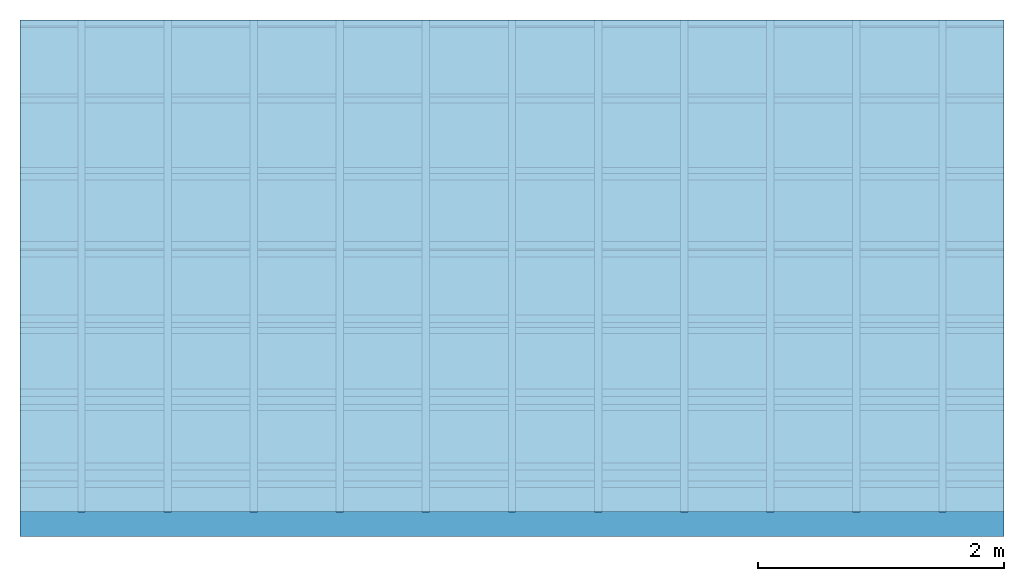
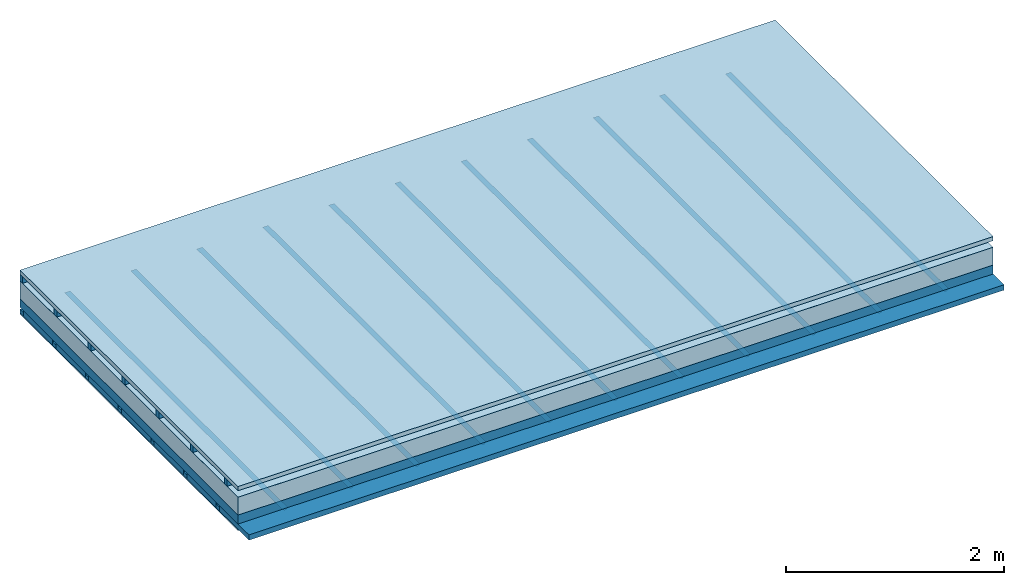
# One storey: 5 members, 4 plates, 1 element without a shape of its own.
"""IFC4 building model written with IfcOpenShell, lengths in metres."""

from ifc_helpers import new_model, si_unit, derived_unit, direction, frame, frame_2d, origin, origin_with_axes, place, context, project, spatial, polyline, rectangle, outline, extrude, material, layer, layer_set, type_object, element, aggregate, save


model = new_model("IFC4")

# Units and contexts
plan_context = context("Plan", 3, precision=1e-05, world=origin(), true_north=direction((0.0, 1.0)))
model_context = context("Model", 3, precision=1e-05, world=origin(), true_north=direction((0.0, 1.0)))
ifc_project = project(units=[si_unit("LENGTHUNIT", "METRE"), derived_unit("SOUNDPRESSUREUNIT", [(si_unit("PRESSUREUNIT", "PASCAL", prefix="MICRO"), 0)]), si_unit("ENERGYUNIT", "JOULE", prefix="MEGA"), si_unit("MASSUNIT", "GRAM", prefix="KILO"), derived_unit("THERMALTRANSMITTANCEUNIT", [(si_unit("POWERUNIT", "WATT"), 1), (si_unit("AREAUNIT", "SQUARE_METRE"), -1), (si_unit("THERMODYNAMICTEMPERATUREUNIT", "KELVIN"), -1)]), derived_unit("AREADENSITYUNIT", [(si_unit("MASSUNIT", "GRAM", prefix="KILO"), 1), (si_unit("AREAUNIT", "SQUARE_METRE"), -1)]), derived_unit("USERDEFINED", [(si_unit("ENERGYUNIT", "JOULE", prefix="MEGA"), 1), (si_unit("AREAUNIT", "SQUARE_METRE"), -1)])], contexts=[plan_context, model_context])

# Site, building, storey
site = spatial("IfcSite", under=ifc_project)
building_placement = place(None, origin())
building = spatial("IfcBuilding", under=site, at=building_placement)
storey_placement = place(building_placement, origin())
storey = spatial("IfcBuildingStorey", under=building, at=storey_placement)

# Slab, members, plates
ifc_material_1 = material(Name="Roof tiles", Category="03.015")
ifc_layer_1 = layer(ifc_material_1, 0.047, Name="Roofing")
ifc_layer_2 = layer(None, 0.072, Name="Battens / profiles")
ifc_material_2 = material(Name="Roofing underlay", Category="09.008")
ifc_layer_3 = layer(ifc_material_2, 0.00018, Name="Under the roof")
ifc_material_3 = material(Category="10.009")
ifc_layer_4 = layer(ifc_material_3, 0.2, Name="Exterior insulation layer 1")
ifc_material_4 = material(Name="no composite action")
ifc_layer_5 = layer(ifc_material_4, 0.0, Name="Bond")
ifc_layer_6 = layer(None, 0.1, Name="Supporting structure")
ifc_layer_7 = layer(ifc_material_4, 0.0, Name="Bond")
ifc_layer_8 = layer(None, 0.02, Name="Coupling")
ifc_layer_9 = layer(None, 0.04, Name="Battens / profiles")
ifc_material_5 = material(Name="Plasterboard type A", Category="03.008")
ifc_layer_10 = layer(ifc_material_5, 0.015, Name="Covering below 1st layer")
ifc_material_6 = material(Name="joints", Category="04.017")
ifc_layer_11 = layer(ifc_material_6, 0.0, Name="Surface below")
ifc_layer_set = layer_set([ifc_layer_1, ifc_layer_2, ifc_layer_3, ifc_layer_4, ifc_layer_5, ifc_layer_6, ifc_layer_7, ifc_layer_8, ifc_layer_9, ifc_layer_10, ifc_layer_11])
slab_type = type_object("IfcSlabType", Name="E0139", PredefinedType="NOTDEFINED", material=ifc_layer_set)
slab_placement = place(None, frame((0.0, 0.0, 0.0), z_axis=(0.0, 0.0, -1.0), x_axis=(1.0, 0.0, 0.0)))
slab = element("IfcSlab", 1, at=slab_placement, inside=storey, type_object=slab_type, material=ifc_layer_set, Name="Slab #1")
ifc_material_7 = material()
member_1_placement = place(slab_placement, origin())
member_1 = element("IfcMember", 2, at=member_1_placement, material=ifc_material_7, Name="Battens / profiles", context=plan_context, shape_type="SweptSolid", body=[
    extrude(rectangle(XDim=0.05, YDim=0.072, at=frame_2d((0.025, 0.036), x_axis=(1.0, 0.0))), frame((0.0, 0.0, 0.047), z_axis=(1.0, 0.0, 0.0), x_axis=(0.0, 1.0, 0.0)), (0.0, 0.0, 1.0), 8.0),
    extrude(rectangle(XDim=0.05, YDim=0.072, at=frame_2d((0.025, 0.036), x_axis=(1.0, 0.0))), frame((0.0, 0.625, 0.047), z_axis=(1.0, 0.0, 0.0), x_axis=(0.0, 1.0, 0.0)), (0.0, 0.0, 1.0), 8.0),
    extrude(rectangle(XDim=0.05, YDim=0.072, at=frame_2d((0.025, 0.036), x_axis=(1.0, 0.0))), frame((0.0, 1.25, 0.047), z_axis=(1.0, 0.0, 0.0), x_axis=(0.0, 1.0, 0.0)), (0.0, 0.0, 1.0), 8.0),
    extrude(rectangle(XDim=0.05, YDim=0.072, at=frame_2d((0.025, 0.036), x_axis=(1.0, 0.0))), frame((0.0, 1.875, 0.047), z_axis=(1.0, 0.0, 0.0), x_axis=(0.0, 1.0, 0.0)), (0.0, 0.0, 1.0), 8.0),
    extrude(rectangle(XDim=0.05, YDim=0.072, at=frame_2d((0.025, 0.036), x_axis=(1.0, 0.0))), frame((0.0, 2.5, 0.047), z_axis=(1.0, 0.0, 0.0), x_axis=(0.0, 1.0, 0.0)), (0.0, 0.0, 1.0), 8.0),
    extrude(rectangle(XDim=0.05, YDim=0.072, at=frame_2d((0.025, 0.036), x_axis=(1.0, 0.0))), frame((0.0, 3.125, 0.047), z_axis=(1.0, 0.0, 0.0), x_axis=(0.0, 1.0, 0.0)), (0.0, 0.0, 1.0), 8.0),
    extrude(rectangle(XDim=0.05, YDim=0.072, at=frame_2d((0.025, 0.036), x_axis=(1.0, 0.0))), frame((0.0, 3.75, 0.047), z_axis=(1.0, 0.0, 0.0), x_axis=(0.0, 1.0, 0.0)), (0.0, 0.0, 1.0), 8.0),
])
ifc_material_8 = material()
member_2_placement = place(slab_placement, origin())
member_2 = element("IfcMember", 3, at=member_2_placement, material=ifc_material_8, Name="Supporting structure", context=plan_context, shape_type="SweptSolid", body=[
    extrude(rectangle(XDim=1.0, YDim=0.1, at=frame_2d((0.5, 0.05), x_axis=(1.0, 0.0))), frame((0.0, 4.0, 0.31918), z_axis=(0.0, -1.0, 0.0), x_axis=(1.0, 0.0, 0.0)), (0.0, 0.0, 1.0), 4.0),
    extrude(rectangle(XDim=1.0, YDim=0.1, at=frame_2d((0.5, 0.05), x_axis=(1.0, 0.0))), frame((1.0, 4.0, 0.31918), z_axis=(0.0, -1.0, 0.0), x_axis=(1.0, 0.0, 0.0)), (0.0, 0.0, 1.0), 4.0),
    extrude(rectangle(XDim=1.0, YDim=0.1, at=frame_2d((0.5, 0.05), x_axis=(1.0, 0.0))), frame((2.0, 4.0, 0.31918), z_axis=(0.0, -1.0, 0.0), x_axis=(1.0, 0.0, 0.0)), (0.0, 0.0, 1.0), 4.0),
    extrude(rectangle(XDim=1.0, YDim=0.1, at=frame_2d((0.5, 0.05), x_axis=(1.0, 0.0))), frame((3.0, 4.0, 0.31918), z_axis=(0.0, -1.0, 0.0), x_axis=(1.0, 0.0, 0.0)), (0.0, 0.0, 1.0), 4.0),
    extrude(rectangle(XDim=1.0, YDim=0.1, at=frame_2d((0.5, 0.05), x_axis=(1.0, 0.0))), frame((4.0, 4.0, 0.31918), z_axis=(0.0, -1.0, 0.0), x_axis=(1.0, 0.0, 0.0)), (0.0, 0.0, 1.0), 4.0),
    extrude(rectangle(XDim=1.0, YDim=0.1, at=frame_2d((0.5, 0.05), x_axis=(1.0, 0.0))), frame((5.0, 4.0, 0.31918), z_axis=(0.0, -1.0, 0.0), x_axis=(1.0, 0.0, 0.0)), (0.0, 0.0, 1.0), 4.0),
    extrude(rectangle(XDim=1.0, YDim=0.1, at=frame_2d((0.5, 0.05), x_axis=(1.0, 0.0))), frame((6.0, 4.0, 0.31918), z_axis=(0.0, -1.0, 0.0), x_axis=(1.0, 0.0, 0.0)), (0.0, 0.0, 1.0), 4.0),
    extrude(rectangle(XDim=1.0, YDim=0.1, at=frame_2d((0.5, 0.05), x_axis=(1.0, 0.0))), frame((7.0, 4.0, 0.31918), z_axis=(0.0, -1.0, 0.0), x_axis=(1.0, 0.0, 0.0)), (0.0, 0.0, 1.0), 4.0),
])
ifc_material_9 = material()
member_3_placement = place(slab_placement, origin())
member_3 = element("IfcMember", 4, at=member_3_placement, material=ifc_material_9, Name="Coupling", context=plan_context, shape_type="SweptSolid", body=[
    extrude(outline(polyline([(0.0, 0.0), (0.06, 0.0), (0.04, 0.02), (0.02, 0.02), (0.0, 0.0)])), frame((0.47, 4.0, 0.41918), z_axis=(0.0, -1.0, 0.0), x_axis=(1.0, 0.0, 0.0)), (0.0, 0.0, 1.0), 4.0),
    extrude(outline(polyline([(0.0, 0.0), (0.06, 0.0), (0.04, 0.02), (0.02, 0.02), (0.0, 0.0)])), frame((1.17, 4.0, 0.41918), z_axis=(0.0, -1.0, 0.0), x_axis=(1.0, 0.0, 0.0)), (0.0, 0.0, 1.0), 4.0),
    extrude(outline(polyline([(0.0, 0.0), (0.06, 0.0), (0.04, 0.02), (0.02, 0.02), (0.0, 0.0)])), frame((1.87, 4.0, 0.41918), z_axis=(0.0, -1.0, 0.0), x_axis=(1.0, 0.0, 0.0)), (0.0, 0.0, 1.0), 4.0),
    extrude(outline(polyline([(0.0, 0.0), (0.06, 0.0), (0.04, 0.02), (0.02, 0.02), (0.0, 0.0)])), frame((2.57, 4.0, 0.41918), z_axis=(0.0, -1.0, 0.0), x_axis=(1.0, 0.0, 0.0)), (0.0, 0.0, 1.0), 4.0),
    extrude(outline(polyline([(0.0, 0.0), (0.06, 0.0), (0.04, 0.02), (0.02, 0.02), (0.0, 0.0)])), frame((3.27, 4.0, 0.41918), z_axis=(0.0, -1.0, 0.0), x_axis=(1.0, 0.0, 0.0)), (0.0, 0.0, 1.0), 4.0),
    extrude(outline(polyline([(0.0, 0.0), (0.06, 0.0), (0.04, 0.02), (0.02, 0.02), (0.0, 0.0)])), frame((3.97, 4.0, 0.41918), z_axis=(0.0, -1.0, 0.0), x_axis=(1.0, 0.0, 0.0)), (0.0, 0.0, 1.0), 4.0),
    extrude(outline(polyline([(0.0, 0.0), (0.06, 0.0), (0.04, 0.02), (0.02, 0.02), (0.0, 0.0)])), frame((4.67, 4.0, 0.41918), z_axis=(0.0, -1.0, 0.0), x_axis=(1.0, 0.0, 0.0)), (0.0, 0.0, 1.0), 4.0),
    extrude(outline(polyline([(0.0, 0.0), (0.06, 0.0), (0.04, 0.02), (0.02, 0.02), (0.0, 0.0)])), frame((5.37, 4.0, 0.41918), z_axis=(0.0, -1.0, 0.0), x_axis=(1.0, 0.0, 0.0)), (0.0, 0.0, 1.0), 4.0),
    extrude(outline(polyline([(0.0, 0.0), (0.06, 0.0), (0.04, 0.02), (0.02, 0.02), (0.0, 0.0)])), frame((6.07, 4.0, 0.41918), z_axis=(0.0, -1.0, 0.0), x_axis=(1.0, 0.0, 0.0)), (0.0, 0.0, 1.0), 4.0),
    extrude(outline(polyline([(0.0, 0.0), (0.06, 0.0), (0.04, 0.02), (0.02, 0.02), (0.0, 0.0)])), frame((6.77, 4.0, 0.41918), z_axis=(0.0, -1.0, 0.0), x_axis=(1.0, 0.0, 0.0)), (0.0, 0.0, 1.0), 4.0),
    extrude(outline(polyline([(0.0, 0.0), (0.06, 0.0), (0.04, 0.02), (0.02, 0.02), (0.0, 0.0)])), frame((7.47, 4.0, 0.41918), z_axis=(0.0, -1.0, 0.0), x_axis=(1.0, 0.0, 0.0)), (0.0, 0.0, 1.0), 4.0),
])
member_4_placement = place(slab_placement, origin())
member_4 = element("IfcMember", 5, at=member_4_placement, material=ifc_material_9, Name="Battens / profiles", context=plan_context, shape_type="SweptSolid", body=[
    extrude(rectangle(XDim=0.06, YDim=0.04, at=frame_2d((0.03, 0.02), x_axis=(1.0, 0.0))), frame((0.0, 0.0, 0.43918), z_axis=(1.0, 0.0, 0.0), x_axis=(0.0, 1.0, 0.0)), (0.0, 0.0, 1.0), 8.0),
    extrude(rectangle(XDim=0.06, YDim=0.04, at=frame_2d((0.03, 0.02), x_axis=(1.0, 0.0))), frame((0.0, 0.6, 0.43918), z_axis=(1.0, 0.0, 0.0), x_axis=(0.0, 1.0, 0.0)), (0.0, 0.0, 1.0), 8.0),
    extrude(rectangle(XDim=0.06, YDim=0.04, at=frame_2d((0.03, 0.02), x_axis=(1.0, 0.0))), frame((0.0, 1.2, 0.43918), z_axis=(1.0, 0.0, 0.0), x_axis=(0.0, 1.0, 0.0)), (0.0, 0.0, 1.0), 8.0),
    extrude(rectangle(XDim=0.06, YDim=0.04, at=frame_2d((0.03, 0.02), x_axis=(1.0, 0.0))), frame((0.0, 1.8, 0.43918), z_axis=(1.0, 0.0, 0.0), x_axis=(0.0, 1.0, 0.0)), (0.0, 0.0, 1.0), 8.0),
    extrude(rectangle(XDim=0.06, YDim=0.04, at=frame_2d((0.03, 0.02), x_axis=(1.0, 0.0))), frame((0.0, 2.4, 0.43918), z_axis=(1.0, 0.0, 0.0), x_axis=(0.0, 1.0, 0.0)), (0.0, 0.0, 1.0), 8.0),
    extrude(rectangle(XDim=0.06, YDim=0.04, at=frame_2d((0.03, 0.02), x_axis=(1.0, 0.0))), frame((0.0, 3.0, 0.43918), z_axis=(1.0, 0.0, 0.0), x_axis=(0.0, 1.0, 0.0)), (0.0, 0.0, 1.0), 8.0),
    extrude(rectangle(XDim=0.06, YDim=0.04, at=frame_2d((0.03, 0.02), x_axis=(1.0, 0.0))), frame((0.0, 3.6, 0.43918), z_axis=(1.0, 0.0, 0.0), x_axis=(0.0, 1.0, 0.0)), (0.0, 0.0, 1.0), 8.0),
])
ifc_material_10 = material(Name="Mineral wool")
member_5_placement = place(slab_placement, origin())
member_5 = element("IfcMember", 6, at=member_5_placement, material=ifc_material_10, Name="Cavity", context=plan_context, shape_type="SweptSolid", body=[
    extrude(rectangle(XDim=0.54, YDim=0.06, at=frame_2d((0.27, 0.03), x_axis=(1.0, 0.0))), frame((0.0, 0.06, 0.41918), z_axis=(1.0, 0.0, 0.0), x_axis=(0.0, 1.0, 0.0)), (0.0, 0.0, 1.0), 8.0),
    extrude(rectangle(XDim=0.54, YDim=0.06, at=frame_2d((0.27, 0.03), x_axis=(1.0, 0.0))), frame((0.0, 0.66, 0.41918), z_axis=(1.0, 0.0, 0.0), x_axis=(0.0, 1.0, 0.0)), (0.0, 0.0, 1.0), 8.0),
    extrude(rectangle(XDim=0.54, YDim=0.06, at=frame_2d((0.27, 0.03), x_axis=(1.0, 0.0))), frame((0.0, 1.26, 0.41918), z_axis=(1.0, 0.0, 0.0), x_axis=(0.0, 1.0, 0.0)), (0.0, 0.0, 1.0), 8.0),
    extrude(rectangle(XDim=0.54, YDim=0.06, at=frame_2d((0.27, 0.03), x_axis=(1.0, 0.0))), frame((0.0, 1.86, 0.41918), z_axis=(1.0, 0.0, 0.0), x_axis=(0.0, 1.0, 0.0)), (0.0, 0.0, 1.0), 8.0),
    extrude(rectangle(XDim=0.54, YDim=0.06, at=frame_2d((0.27, 0.03), x_axis=(1.0, 0.0))), frame((0.0, 2.46, 0.41918), z_axis=(1.0, 0.0, 0.0), x_axis=(0.0, 1.0, 0.0)), (0.0, 0.0, 1.0), 8.0),
    extrude(rectangle(XDim=0.54, YDim=0.06, at=frame_2d((0.27, 0.03), x_axis=(1.0, 0.0))), frame((0.0, 3.06, 0.41918), z_axis=(1.0, 0.0, 0.0), x_axis=(0.0, 1.0, 0.0)), (0.0, 0.0, 1.0), 8.0),
    extrude(rectangle(XDim=0.54, YDim=0.06, at=frame_2d((0.27, 0.03), x_axis=(1.0, 0.0))), frame((0.0, 3.66, 0.41918), z_axis=(1.0, 0.0, 0.0), x_axis=(0.0, 1.0, 0.0)), (0.0, 0.0, 1.0), 8.0),
])
plate_1_placement = place(slab_placement, origin())
plate_1 = element("IfcPlate", 7, at=plate_1_placement, material=ifc_material_1, Name="Roofing", context=plan_context, shape_type="SweptSolid", body=[
    extrude(rectangle(XDim=8.0, YDim=4.0, at=frame_2d((4.0, 2.0), x_axis=(1.0, 0.0))), origin_with_axes(), (0.0, 0.0, 1.0), 0.047),
])
plate_2_placement = place(slab_placement, origin())
plate_2 = element("IfcPlate", 8, at=plate_2_placement, material=ifc_material_2, Name="Under the roof", context=plan_context, shape_type="SweptSolid", body=[
    extrude(rectangle(XDim=8.0, YDim=4.0, at=frame_2d((4.0, 2.0), x_axis=(1.0, 0.0))), frame((0.0, 0.0, 0.119), z_axis=(0.0, 0.0, 1.0), x_axis=(1.0, 0.0, 0.0)), (0.0, 0.0, 1.0), 0.00018),
])
plate_3_placement = place(slab_placement, origin())
plate_3 = element("IfcPlate", 9, at=plate_3_placement, material=ifc_material_3, Name="Exterior insulation layer 1", context=plan_context, shape_type="SweptSolid", body=[
    extrude(rectangle(XDim=8.0, YDim=4.0, at=frame_2d((4.0, 2.0), x_axis=(1.0, 0.0))), frame((0.0, 0.0, 0.11918), z_axis=(0.0, 0.0, 1.0), x_axis=(1.0, 0.0, 0.0)), (0.0, 0.0, 1.0), 0.2),
])
plate_4_placement = place(slab_placement, origin())
plate_4 = element("IfcPlate", 10, at=plate_4_placement, material=ifc_material_5, Name="Covering below 1st layer", context=plan_context, shape_type="SweptSolid", body=[
    extrude(rectangle(XDim=8.0, YDim=4.0, at=frame_2d((4.0, 2.0), x_axis=(1.0, 0.0))), frame((0.0, 0.0, 0.47918), z_axis=(0.0, 0.0, 1.0), x_axis=(1.0, 0.0, 0.0)), (0.0, 0.0, 1.0), 0.015),
])
aggregate(slab, [plate_1, member_1, plate_2, plate_3, member_2, member_3, member_4, member_5, plate_4])

save(model, "model.ifc")
